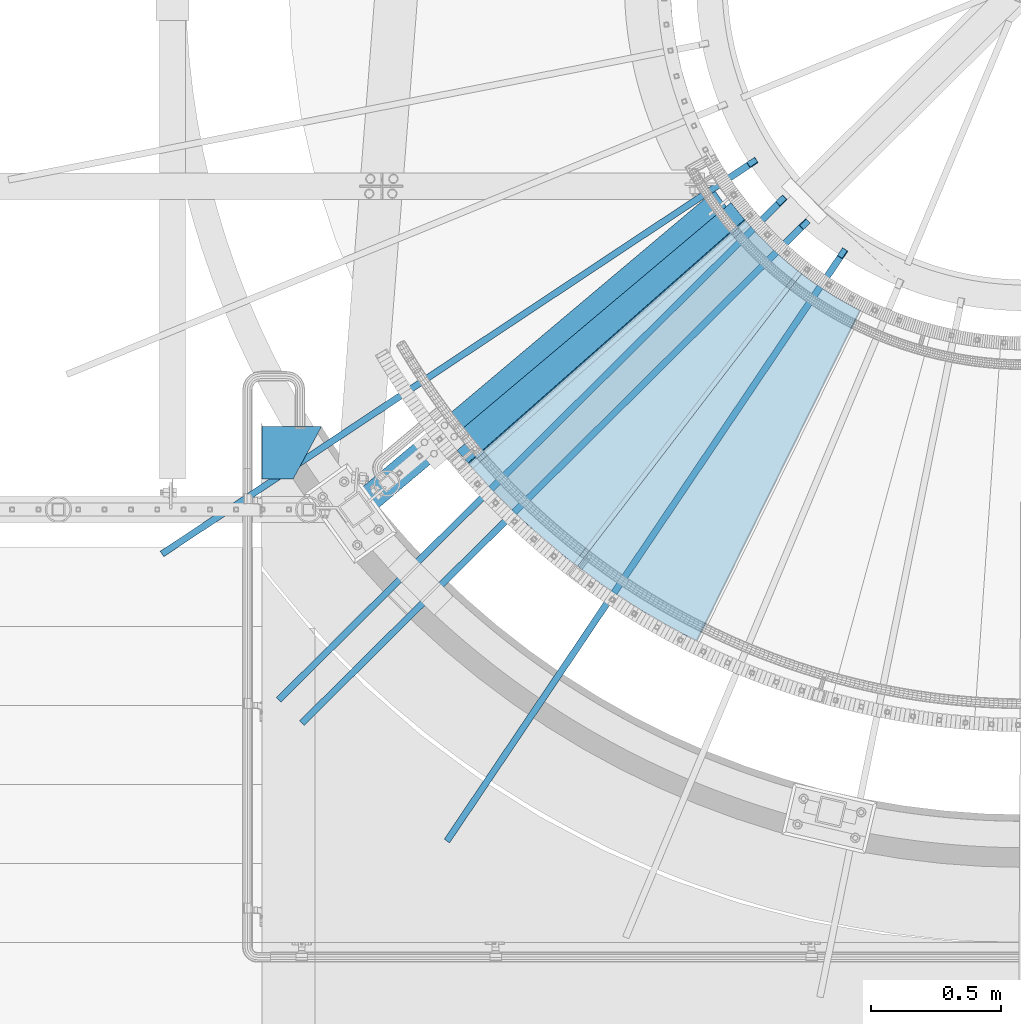
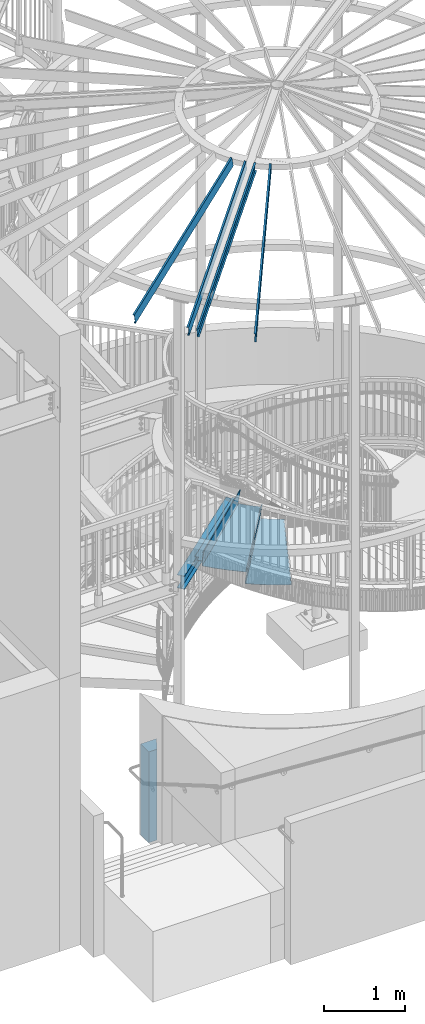
# One storey, part 338 of 975: 9 beams.
"""IFC2X3 building model written with IfcOpenShell, lengths in millimetres."""

import ifcopenshell
import ifcopenshell.guid

model = None  # the IFC model being written
_history = None  # IfcOwnerHistory: only IFC2X3 demands one
_inside = {}  # id of a spatial element -> (the spatial element, [elements in it])
_under = {}  # id of a project, library or spatial element -> (it, [spatial elements below it])
_declared = {}  # id of a project -> (the project, [libraries it declares])
_typed = {}  # id of a type object -> (the type object, [elements of that type])
_made_of = {}  # id of a material, layer set ... -> (it, [elements and type objects made of it])


def new_model(schema):
    """Start an empty IFC model of exactly this schema.

    Asked for "IFC4X3", IfcOpenShell would pick the latest addendum, in which some entities
    have other attributes; the version numbers below select the first issue.
    IFC2X3 requires an IfcOwnerHistory on every rooted entity: one is made here for all.
    """
    global model, _history
    if schema == "IFC4X3":
        model = ifcopenshell.file(schema_version=(4, 3, 0, 0))
    else:
        model = ifcopenshell.file(schema=schema)
    _inside.clear()
    _under.clear()
    _declared.clear()
    _typed.clear()
    _made_of.clear()
    _history = None
    if model.schema == "IFC2X3":
        org = make("IfcOrganization", Name="unknown")
        user = make(
            "IfcPersonAndOrganization",
            ThePerson=make("IfcPerson", FamilyName="unknown"),
            TheOrganization=org,
        )
        app = make(
            "IfcApplication",
            ApplicationDeveloper=org,
            Version="unknown",
            ApplicationFullName="unknown",
            ApplicationIdentifier="unknown",
        )
        _history = make(
            "IfcOwnerHistory",
            OwningUser=user,
            OwningApplication=app,
            ChangeAction="ADDED",
            CreationDate=0,
        )
    return model


def make(cls, **values):
    """One entity of the class cls with the attributes given. An attribute that is None is left unset."""
    return model.create_entity(
        cls, **{name: value for name, value in values.items() if value is not None}
    )


def rooted(cls, **values):
    """An entity with a GlobalId (a new one), such as an element, a storey or a relation."""
    return make(cls, GlobalId=ifcopenshell.guid.new(), OwnerHistory=_history, **values)


def si_unit(unit_type, name, prefix=None):
    """IfcSIUnit, for example si_unit("LENGTHUNIT", "METRE", prefix="MILLI")."""
    return make("IfcSIUnit", UnitType=unit_type, Prefix=prefix, Name=name)


def assignment(units):
    """IfcUnitAssignment: the units of a project."""
    return None if units is None else make("IfcUnitAssignment", Units=units)


def point(xyz):
    """IfcCartesianPoint."""
    return None if xyz is None else make("IfcCartesianPoint", Coordinates=xyz)


def direction(xyz):
    """IfcDirection."""
    return None if xyz is None else make("IfcDirection", DirectionRatios=xyz)


def frame(location, z_axis=None, x_axis=None):
    """IfcAxis2Placement3D, a coordinate frame: its origin and axes. An axis left out is left unset."""
    return make(
        "IfcAxis2Placement3D",
        Location=point(location),
        Axis=direction(z_axis),
        RefDirection=direction(x_axis),
    )


def origin_with_axes():
    """The frame at (0, 0, 0) with the z axis (0, 0, 1) and the x axis (1, 0, 0) written out."""
    return frame((0.0, 0.0, 0.0), z_axis=(0.0, 0.0, 1.0), x_axis=(1.0, 0.0, 0.0))


def place(relative_to, where):
    """IfcLocalPlacement: puts the frame where relative to a parent placement (None: the world)."""
    return make(
        "IfcLocalPlacement", PlacementRelTo=relative_to, RelativePlacement=where
    )


def context(
    kind, dimensions, precision=None, world=None, true_north=None, identifier=None
):
    """IfcGeometricRepresentationContext, for example the 3D "Model" context."""
    return make(
        "IfcGeometricRepresentationContext",
        ContextIdentifier=identifier,
        ContextType=kind,
        CoordinateSpaceDimension=dimensions,
        Precision=precision,
        WorldCoordinateSystem=world,
        TrueNorth=true_north,
    )


def subcontext(parent, identifier, kind, view, scale=None):
    """IfcGeometricRepresentationSubContext, for example "Body" below "Model"."""
    return make(
        "IfcGeometricRepresentationSubContext",
        ContextIdentifier=identifier,
        ContextType=kind,
        ParentContext=parent,
        TargetScale=scale,
        TargetView=view,
    )


def project(units=None, contexts=None):
    """IfcProject with its units and contexts."""
    return rooted(
        "IfcProject",
        Name="project",
        RepresentationContexts=contexts,
        UnitsInContext=assignment(units),
    )


def spatial(cls, under=None, at=None, **own):
    """A site, building, storey or space (cls), placed at a placement, below another one or the project."""
    s = rooted(cls, ObjectPlacement=at, **own)
    if under is not None:
        _under.setdefault(under.id(), (under, []))[1].append(s)
    return s


def faces_of(points, faces, orient=None, outer=None):
    """IfcFace entities. A face is a list of loops; a loop is a list of indices into points, from 0.

    orient and outer hold one flag for each loop. By default every Orientation is true, the
    first loop of a face is its IfcFaceOuterBound and the others are IfcFaceBound.
    """
    made = []
    for i, loops in enumerate(faces):
        bounds = []
        for j, loop in enumerate(loops):
            is_outer = j == 0 if outer is None else outer[i][j]
            bounds.append(
                make(
                    "IfcFaceOuterBound" if is_outer else "IfcFaceBound",
                    Bound=make("IfcPolyLoop", Polygon=[points[k] for k in loop]),
                    Orientation=True if orient is None else orient[i][j],
                )
            )
        made.append(make("IfcFace", Bounds=bounds))
    return made


def faceted_brep(points, faces, orient=None, outer=None, voids=None):
    """IfcFacetedBrep: a solid bounded by flat faces; with voids (closed shells), ...WithVoids."""
    shared = [point(p) for p in points]
    hull = make("IfcClosedShell", CfsFaces=faces_of(shared, faces, orient, outer))
    if voids is None:
        return make("IfcFacetedBrep", Outer=hull)
    return make(
        "IfcFacetedBrepWithVoids",
        Outer=hull,
        Voids=[
            make(cls, CfsFaces=faces_of(shared, fs, o, b)) for cls, fs, o, b in voids
        ],
    )


def shape(context_of_items, identifier, shape_type, items):
    """IfcShapeRepresentation: the items that make up one representation, for example the "Body"."""
    return make(
        "IfcShapeRepresentation",
        ContextOfItems=context_of_items,
        RepresentationIdentifier=identifier,
        RepresentationType=shape_type,
        Items=items,
    )


def material(Name=None, Category=None):
    """IfcMaterial."""
    return make("IfcMaterial", Name=Name, Category=Category)


def made_of(thing, what):
    """Note that an element or type object is made of a material, layer set ...; save() writes the relation."""
    if what is not None:
        _made_of.setdefault(what.id(), (what, []))[1].append(thing)
    return thing


def type_object(cls, material=None, **own):
    """A type object (cls), such as IfcWallType, which elements share."""
    return made_of(rooted(cls, **own), material)


def element(
    cls,
    number,
    at=None,
    inside=None,
    cuts=None,
    type_object=None,
    material=None,
    context=None,
    identifier="Body",
    shape_type=None,
    held_by="IfcProductDefinitionShape",
    body=None,
    shapes=None,
    **own,
):
    """One element of the class cls, such as IfcWall. Its Tag is "e" and its number.

    at: its placement. inside: the storey or other place that contains it. cuts: it is an
    opening in that element (IfcRelVoidsElement). A single representation is given by context,
    identifier, shape_type and body (its items); several are given by shapes. held_by: the class
    of the entity that holds the representations. save() writes the other relations.
    """
    e = rooted(cls, Tag="e%d" % number, ObjectPlacement=at, **own)
    if body is not None:
        shapes = [shape(context, identifier, shape_type, body)]
    if shapes is not None:
        e.Representation = make(held_by, Representations=shapes)
    if inside is not None:
        _inside.setdefault(inside.id(), (inside, []))[1].append(e)
    if cuts is not None:
        rooted(
            "IfcRelVoidsElement", RelatingBuildingElement=cuts, RelatedOpeningElement=e
        )
    if type_object is not None:
        _typed.setdefault(type_object.id(), (type_object, []))[1].append(e)
    return made_of(e, material)


def aggregate(whole, parts):
    """IfcRelAggregates: a whole, such as a stair, and the parts it consists of."""
    return rooted("IfcRelAggregates", RelatingObject=whole, RelatedObjects=parts)


def save(model, path):
    """Write the relations noted so far, then the file.

    IfcRelAggregates (storeys below a building ...), IfcRelContainedInSpatialStructure (elements
    in a storey), IfcRelDefinesByType, IfcRelAssociatesMaterial and IfcRelDeclares: one each for
    every whole, place, type object, material and project.
    """
    for whole, parts in _under.values():
        aggregate(whole, parts)
    for where, things in _inside.values():
        rooted(
            "IfcRelContainedInSpatialStructure",
            RelatedElements=things,
            RelatingStructure=where,
        )
    for kind, things in _typed.values():
        rooted("IfcRelDefinesByType", RelatedObjects=things, RelatingType=kind)
    for what, things in _made_of.values():
        rooted("IfcRelAssociatesMaterial", RelatedObjects=things, RelatingMaterial=what)
    for by, libraries in _declared.values():
        rooted("IfcRelDeclares", RelatingContext=by, RelatedDefinitions=libraries)
    model.write(path)


model = new_model("IFC2X3")

# Units and contexts
model_context = context("Model", 3, precision=1e-05, world=origin_with_axes())
body_context = subcontext(model_context, "Body", "Model", "MODEL_VIEW")
ifc_project = project(units=[si_unit("LENGTHUNIT", "METRE", prefix="MILLI"), si_unit("AREAUNIT", "SQUARE_METRE"), si_unit("VOLUMEUNIT", "CUBIC_METRE"), si_unit("MASSUNIT", "GRAM", prefix="KILO"), si_unit("TIMEUNIT", "SECOND"), si_unit("PLANEANGLEUNIT", "RADIAN"), si_unit("SOLIDANGLEUNIT", "STERADIAN"), si_unit("THERMODYNAMICTEMPERATUREUNIT", "DEGREE_CELSIUS"), si_unit("LUMINOUSINTENSITYUNIT", "LUMEN")], contexts=[model_context])

# Site, building, storey
site_placement = place(None, origin_with_axes())
site = spatial("IfcSite", under=ifc_project, at=site_placement, CompositionType="ELEMENT")
building_placement = place(site_placement, origin_with_axes())
building = spatial("IfcBuilding", under=site, at=building_placement, Name="Undefined", CompositionType="ELEMENT")
storey_placement = place(building_placement, origin_with_axes())
storey = spatial("IfcBuildingStorey", under=building, at=storey_placement, Name="Undefined", CompositionType="ELEMENT", Elevation=0.0)

# Beams
ifc_material_1 = material(Name="STEEL/A36")
beam_type_1 = type_object("IfcBeamType", PredefinedType="NOTDEFINED")
beam_1_placement = place(storey_placement, frame((32823.4648974036, 2327.37322086433, 4143.34195838398), z_axis=(-0.86418478726382, -0.503174575531979, 8.30155840958467e-10), x_axis=(0.355798155040197, -0.611070923069167, 0.707106781080049)))
element("IfcBeam", 1, at=beam_1_placement, inside=storey, type_object=beam_type_1, material=ifc_material_1, Name="TREAD", context=body_context, shape_type="Brep", body=[
    faceted_brep([(160.865457729587, -448.186924760857, 560.711126159746), (158.620393733536, -450.431988758119, 560.711126157043), (193.966216339091, -485.777811352988, 552.004375820034), (196.21128030732, -483.532747384082, 552.004375822675), (203.887068634338, -491.208535643013, 614.32545793079), (201.642004632895, -493.45359964513, 614.325457928149), (49.7927349215133, -337.114201961485, -791.08236047571), (47.5476709198538, -339.35926596382, -791.082360478347), (-6.49137455243726, -285.320220507845, -779.860507265057), (-4.24631055867758, -283.075156512879, -779.860507262361), (66.437802308692, -335.979336534963, -793.502619428495), (56.3071310127107, -343.628597994977, -793.115412720523), (53.7487404151489, -345.560335457225, -793.01762786691), (54.0919957188744, -341.413461775162, -792.424099714608), (64.5845451579717, -333.490960101732, -792.825137753654), (248.701623596196, -536.023091227627, 602.134831213494), (259.197053542079, -528.103470062568, 601.754434690294), (261.055176792581, -530.596712595621, 601.111823144849), (250.921725105154, -538.24319290819, 601.479100122608), (248.362633442506, -540.174228440612, 601.571851715846), (214.846370562875, -502.167837565145, 612.134347570151), (212.601306559884, -504.412901568812, 612.134347567509)], [[[0, 1, 2, 3]], [[4, 3, 2, 5]], [[6, 7, 8, 9]], [[10, 11, 12, 7, 6, 13, 14]], [[14, 13, 15, 16]], [[10, 14, 16, 17]], [[11, 10, 17, 18]], [[12, 11, 18, 19]], [[17, 16, 15, 20, 21, 19, 18]], [[21, 20, 4, 5]], [[1, 8, 7, 12, 19, 21, 5, 2]], [[9, 8, 1, 0]], [[20, 15, 13, 6, 9, 0, 3, 4]]]),
])
beam_type_2 = type_object("IfcBeamType", PredefinedType="NOTDEFINED")
beam_2_placement = place(storey_placement, frame((33389.0351361402, 1675.41360917162, 3892.51695574219), z_axis=(-0.608231640500483, -0.793759580410902, 6.46417902316899e-10), x_axis=(0.561272782183221, -0.430084717140374, 0.707106781230806)))
element("IfcBeam", 2, at=beam_2_placement, inside=storey, type_object=beam_type_2, material=ifc_material_1, Name="TREAD", context=body_context, shape_type="Brep", body=[
    faceted_brep([(25.4000001621371, 1.5874997143419, 653.28751700326), (1.61144271260127e-08, 1.58750000026703, 653.458911680114), (-1.96268956642598e-08, -1.58749999973588, 653.437487347819), (15.8745748038546, -1.5875001784334, 653.330368544412), (-120.373022221533, -103.76749224318, 653.560250726816), (-154.208562872085, -137.603032237963, 653.560249286144), (-49.0005534961238, -242.811041643061, 652.140399877677), (-46.7554894721361, -240.565977619684, 652.140399877557), (-149.718432901582, -137.603030988068, 653.529952160912), (-118.287540217565, -106.172138299769, 653.529952144057), (82.2634121742994, -374.075007349978, 638.193006315465), (84.508476198167, -371.829943326711, 638.193006315345), (212.601306559884, -504.412901568812, 612.134347567509), (214.846370562875, -502.167837565145, 612.134347570151), (261.055176792581, -530.596712595621, 601.111823144849), (259.197053542079, -528.103470062568, 601.754434690294), (248.701623596196, -536.023091227627, 602.134831213494), (248.362633442506, -540.174228440612, 601.571851715846), (250.921725105154, -538.24319290819, 601.479100122608), (25.4000001865188, 1.58749971376164, -768.618736200977), (-118.287540216395, -106.172138302336, -768.542582766611), (-149.718433278054, -137.603031368186, -768.542582749815), (-92.8426928760819, -194.478774201189, -768.783692225286), (-95.087756899542, -196.723838224048, -768.783692225159), (-154.208562871598, -137.603032235413, -768.533065523057), (-120.373022220361, -103.767492245748, -768.533065418116), (15.8745748282345, -1.58750017901184, -768.605275732323), (-1.58015609486029e-08, -1.58750000031432, -768.571627720263), (1.99397618416697e-08, 1.58749999968677, -768.564897939472), (-21.2434099455131, -266.078057151808, -776.330856581004), (-23.4884739689005, -268.323121174595, -776.330856580884), (49.7927349215133, -337.114201961485, -791.08236047571), (47.5476709198538, -339.35926596382, -791.082360478347), (66.437802308692, -335.979336534963, -793.502619428495), (56.3071310127107, -343.628597994977, -793.115412720523), (53.7487404151489, -345.560335457225, -793.01762786691), (54.0919957188744, -341.413461775162, -792.424099714608), (64.5845451579717, -333.490960101732, -792.825137753654)], [[[0, 1, 2, 3, 4, 5, 6, 7, 8, 9]], [[7, 6, 10, 11]], [[11, 10, 12, 13]], [[14, 15, 16, 13, 12, 17, 18]], [[19, 20, 21, 22, 23, 24, 25, 26, 27, 28]], [[29, 30, 23, 22]], [[31, 32, 30, 29]], [[33, 34, 35, 32, 31, 36, 37]], [[34, 33, 14, 18]], [[35, 34, 18, 17]], [[10, 6, 5, 24, 23, 30, 32, 35, 17, 12]], [[25, 24, 5, 4]], [[26, 25, 4, 3]], [[27, 26, 3, 2]], [[28, 27, 2, 1]], [[19, 28, 1, 0]], [[20, 19, 0, 9]], [[20, 9, 8, 21]], [[36, 31, 29, 22, 21, 8, 7, 11, 13, 16]], [[37, 36, 16, 15]], [[33, 37, 15, 14]]]),
])
beam_3_placement = place(storey_placement, frame((33079.8874394977, 1968.62223851591, 4070.31695574219), z_axis=(-0.750408185982426, -0.660974700280249, 2.21917616727296e-10), x_axis=(0.467379693000938, -0.530618717001168, 0.707106781001557)))
element("IfcBeam", 3, at=beam_3_placement, inside=storey, type_object=beam_type_2, material=ifc_material_1, Name="TREAD", context=body_context, shape_type="Brep", body=[
    faceted_brep([(25.4000001621371, 1.5874997143419, 653.28751700326), (1.61144271260127e-08, 1.58750000026703, 653.458911680114), (-1.96268956642598e-08, -1.58749999973588, 653.437487347819), (15.8745748038546, -1.5875001784334, 653.330368544412), (-120.373022221533, -103.76749224318, 653.560250726816), (-154.208562872085, -137.603032237963, 653.560249286144), (-49.0005534961238, -242.811041643061, 652.140399877677), (-46.7554894721361, -240.565977619684, 652.140399877557), (-149.718432901582, -137.603030988068, 653.529952160912), (-118.287540217565, -106.172138299769, 653.529952144057), (82.2634121742994, -374.075007349978, 638.193006315465), (84.508476198167, -371.829943326711, 638.193006315345), (212.601306559884, -504.412901568812, 612.134347567509), (214.846370562875, -502.167837565145, 612.134347570151), (261.055176792581, -530.596712595621, 601.111823144849), (259.197053542079, -528.103470062568, 601.754434690294), (248.701623596196, -536.023091227627, 602.134831213494), (248.362633442506, -540.174228440612, 601.571851715846), (250.921725105154, -538.24319290819, 601.479100122608), (25.4000001865188, 1.58749971376164, -768.618736200977), (-118.287540216395, -106.172138302336, -768.542582766611), (-149.718433278054, -137.603031368186, -768.542582749815), (-92.8426928760819, -194.478774201189, -768.783692225286), (-95.087756899542, -196.723838224048, -768.783692225159), (-154.208562871598, -137.603032235413, -768.533065523057), (-120.373022220361, -103.767492245748, -768.533065418116), (15.8745748282345, -1.58750017901184, -768.605275732323), (-1.58015609486029e-08, -1.58750000031432, -768.571627720263), (1.99397618416697e-08, 1.58749999968677, -768.564897939472), (-21.2434099455131, -266.078057151808, -776.330856581004), (-23.4884739689005, -268.323121174595, -776.330856580884), (49.7927349215133, -337.114201961485, -791.08236047571), (47.5476709198538, -339.35926596382, -791.082360478347), (66.437802308692, -335.979336534963, -793.502619428495), (56.3071310127107, -343.628597994977, -793.115412720523), (53.7487404151489, -345.560335457225, -793.01762786691), (54.0919957188744, -341.413461775162, -792.424099714608), (64.5845451579717, -333.490960101732, -792.825137753654)], [[[0, 1, 2, 3, 4, 5, 6, 7, 8, 9]], [[7, 6, 10, 11]], [[11, 10, 12, 13]], [[14, 15, 16, 13, 12, 17, 18]], [[19, 20, 21, 22, 23, 24, 25, 26, 27, 28]], [[29, 30, 23, 22]], [[31, 32, 30, 29]], [[33, 34, 35, 32, 31, 36, 37]], [[34, 33, 14, 18]], [[35, 34, 18, 17]], [[10, 6, 5, 24, 23, 30, 32, 35, 17, 12]], [[25, 24, 5, 4]], [[26, 25, 4, 3]], [[27, 26, 3, 2]], [[28, 27, 2, 1]], [[19, 28, 1, 0]], [[20, 19, 0, 9]], [[20, 9, 8, 21]], [[36, 31, 29, 22, 21, 8, 7, 11, 13, 16]], [[37, 36, 16, 15]], [[33, 37, 15, 14]]]),
])
ifc_material_2 = material(Name="STEEL/A992")
beam_type_3 = type_object("IfcBeamType", Name="W8X10", PredefinedType="NOTDEFINED")
beam_4_placement = place(storey_placement, frame((32150.2688578099, 1365.04770757634, 3836.9875), z_axis=(0.0, 0.0, 1.0), x_axis=(0.76502246600244, 0.644003592002052, 0.0)))
element("IfcBeam", 4, at=beam_4_placement, inside=storey, type_object=beam_type_3, material=ifc_material_2, Name="BEAM", ObjectType="W8X10", context=body_context, shape_type="Brep", body=[
    faceted_brep([(67.4998381363475, -50.8000000000211, -95.25), (67.4998381363475, -50.8000000000211, -100.0125), (1843.49825566609, -50.8000000005122, -100.0125), (1843.49825566609, -50.8000000005122, -95.25), (67.4998381363257, -2.38125000001673, -95.25), (1847.13968006969, -2.3812500005115, -95.25), (67.4998381363257, -2.38125000001673, 95.25), (1847.13968006969, -2.3812500005115, 95.25), (67.4998381363475, -50.8000000000211, 95.25), (1843.49825566609, -50.8000000005122, 95.25), (67.4998381363475, -50.8000000000211, 100.0125), (1843.49825566609, -50.8000000005122, 100.0125), (67.4998381363039, 50.7999999999847, 100.0125), (1851.13927736546, 50.7999999994936, 100.0125), (67.4998381363039, 50.7999999999847, 95.25), (1851.13927736546, 50.7999999994936, 95.25), (67.4998381363257, 2.38124999998035, 95.25), (1847.49785296185, 2.38124999948923, 95.25), (67.4998381363257, 2.38124999998035, -95.25), (1847.49785296185, 2.38124999948923, -95.25), (67.4998381363039, 50.7999999999847, -95.25), (1851.13927736546, 50.7999999994936, -95.25), (67.4998381363039, 50.7999999999847, -100.0125), (1851.13927736546, 50.7999999994936, -100.0125)], [[[0, 1, 2, 3]], [[4, 0, 3, 5]], [[6, 4, 5, 7]], [[8, 6, 7, 9]], [[10, 8, 9, 11]], [[12, 10, 11, 13]], [[14, 12, 13, 15]], [[16, 14, 15, 17]], [[18, 16, 17, 19]], [[20, 18, 19, 21]], [[1, 0, 4, 6, 8, 10, 12, 14, 16, 18, 20, 22]], [[1, 22, 23, 2]], [[19, 17, 15, 13, 11, 9, 7, 5, 3, 2, 23, 21]], [[22, 20, 21, 23]]]),
])
ifc_material_3 = material(Name="STEEL/Zero_Density")
beam_type_4 = type_object("IfcBeamType", PredefinedType="NOTDEFINED")
for number, where, z_axis, x_axis, name in (
    (5, (33679.8002631945, 2704.03227224674, 8885.0313138005), (-0.202158604335491, -0.134009290222394, 0.970140922148539), (-0.808612057787423, -0.536022339859084, -0.242541936936238), "STUD"),
    (6, (34027.7974794488, 2353.66757932804, 8885.0313138005), (-0.135487061204178, -0.201171189303167, 0.970140922155438), (-0.541933260795873, -0.804662506696911, -0.242541936908643), "STUD"),
    (7, (33791.4781567808, 2556.84511787571, 8885.0313138005), (-0.17213026717781, -0.170873527176511, 0.970140922150774), (-0.688502032793625, -0.683475207795133, -0.242541936927299), "STUD"),
    (8, (31953.7973780767, 553.724905309903, 8206.16015010101), (-0.17213026717781, -0.170873527176511, 0.970140922150774), (0.688502112820797, 0.683475127155154, 0.242541936995531), "STUD"),
):
    element("IfcBeam", number, at=place(storey_placement, frame(where, z_axis=z_axis, x_axis=x_axis)), inside=storey, type_object=beam_type_4, material=ifc_material_3, Name=name, context=body_context, shape_type="Brep", body=[
        faceted_brep([(-1.67347025126219e-10, 12.6999999998588, -76.2000000000985), (1.96450855582952e-10, 12.7000000001644, 76.2000000001021), (2798.98467503002, 12.7000000041553, 76.2000000028588), (2798.98467502966, 12.7000000038533, -76.1999999973427), (1.74622982740402e-10, -12.6999999998661, 76.2000000000985), (2798.98467503, -12.6999999958753, 76.2000000028534), (1.67347025126219e-10, -12.6999999998698, 73.0250000000947), (2798.98467502999, -12.6999999958789, 73.0250000028504), (1.89174897968769e-10, 9.52500000015425, 73.0250000000974), (2798.98467503001, 9.52500000414511, 73.0250000028532), (-1.60071067512035e-10, 9.52499999986321, -73.0250000000938), (2798.98467502966, 9.52500000385407, -73.0249999973398), (-1.81898940354586e-10, -12.7000000001608, -73.0250000000965), (2798.98467502964, -12.6999999961699, -73.0249999973416), (-1.92812876775861e-10, -12.7000000001717, -76.2000000001003), (2798.98467502963, -12.6999999961772, -76.1999999973455)], [[[0, 1, 2, 3]], [[1, 4, 5, 2]], [[4, 6, 7, 5]], [[6, 8, 9, 7]], [[8, 10, 11, 9]], [[10, 12, 13, 11]], [[12, 14, 15, 13]], [[14, 0, 3, 15]], [[5, 7, 9, 11, 13, 15, 3, 2]], [[14, 12, 10, 8, 6, 4, 1, 0]]]),
    ])
ifc_material_4 = material(Name="CONCRETE/5000")
beam_type_5 = type_object("IfcBeamType", PredefinedType="NOTDEFINED")
beam_5_placement = place(storey_placement, frame((31788.1000372195, 1583.70486581335, 685.8), z_axis=(0.0, 0.0, 1.0), x_axis=(1.0, 0.0, 0.0)))
element("IfcBeam", 9, at=beam_5_placement, inside=storey, type_object=beam_type_5, material=ifc_material_4, Name="WALL", context=body_context, shape_type="Brep", body=[
    faceted_brep([(-1.0550138540566e-10, -101.6, -685.8), (-1.0550138540566e-10, -101.6, 685.8), (1.16415321826935e-10, 101.600000000001, 685.8), (1.16415321826935e-10, 101.600000000001, -685.8), (228.599917461837, 101.600000000009, 685.8), (228.599917461837, 101.600000000009, -685.8), (119.015478994239, -101.599999999996, -685.8), (119.015478994239, -101.599999999996, 685.8)], [[[0, 1, 2, 3]], [[3, 2, 4, 5]], [[0, 3, 5, 6]], [[1, 0, 6, 7]], [[2, 1, 7, 4]], [[6, 5, 4, 7]]]),
])

save(model, "model.ifc")
